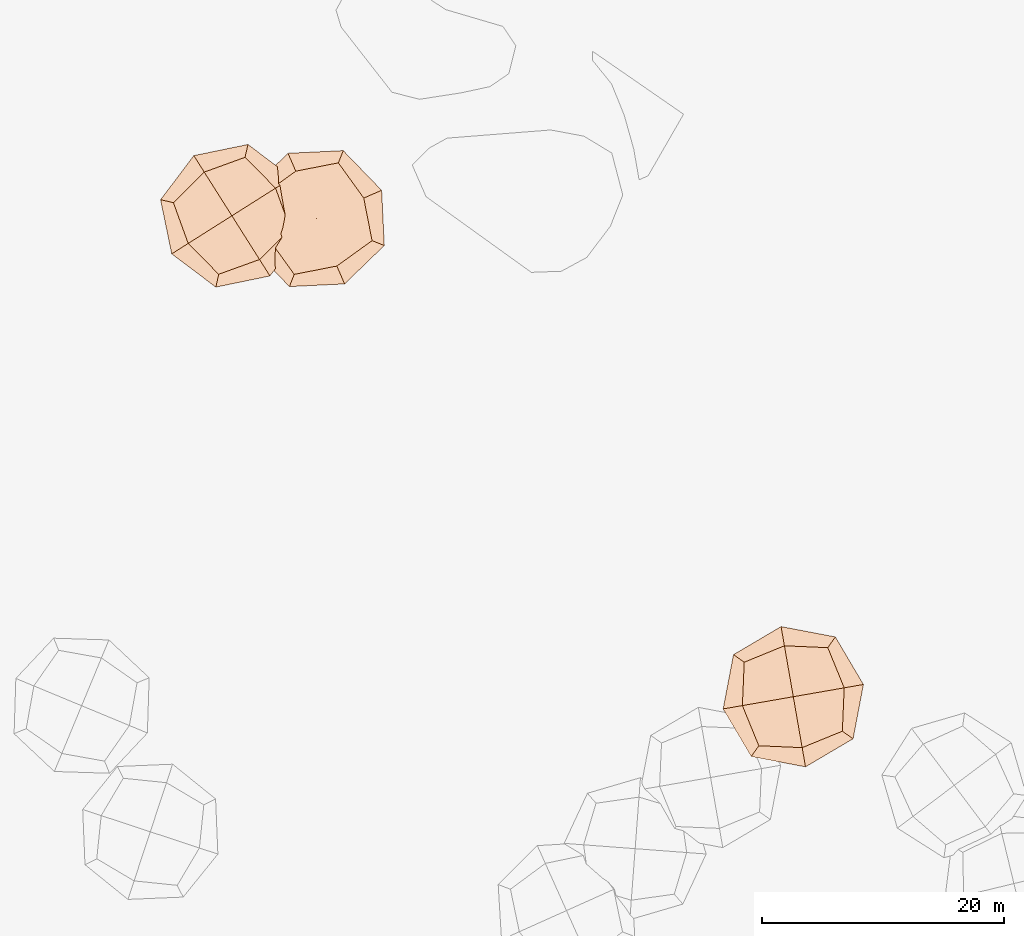
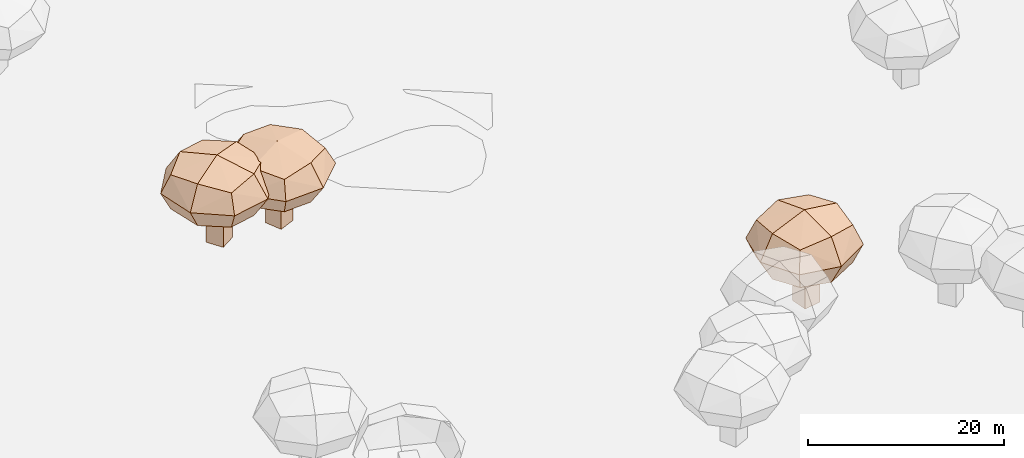
# Not in any storey, part 12 of 92: 3 geographic elements.
"""IFC4 model written with IfcOpenShell, lengths in metres."""

from ifc_helpers import new_model, si_unit, origin_with_axes, place, context, subcontext, project, spatial, triangles, material, element, save


model = new_model("IFC4")

# Units and contexts
model_context = context("Model", 3, precision=1e-05, world=origin_with_axes())
body_context = subcontext(model_context, "Body", "Model", "MODEL_VIEW")
ifc_project = project(units=[si_unit("VOLUMEUNIT", "CUBIC_METRE"), si_unit("LENGTHUNIT", "METRE"), si_unit("AREAUNIT", "SQUARE_METRE")], contexts=[model_context])

# Site
site_placement = place(None, origin_with_axes())
site = spatial("IfcSite", under=ifc_project, at=site_placement)

# Geographic elements
ifc_material = material(Name="tree")
geographic_element_1_placement = place(site_placement, origin_with_axes())
element("IfcGeographicElement", 1, at=geographic_element_1_placement, inside=site, material=ifc_material, Name="cw_instances_tree_168", context=body_context, shape_type="Tessellation", body=[
    triangles([(407.0424773080425, -716.6059607434237, 6.081787157617667), (407.0424773080425, -716.6059607434237, 6.081787157617667), (407.0424773080425, -716.6059607434237, 6.081787157617667), (407.0424773080425, -716.6059607434237, 0.0), (407.0424773080425, -716.6059607434237, 0.0), (407.0424773080425, -716.6059607434237, 0.0), (405.352289608444, -717.6751967043442, 6.081787157617667), (405.352289608444, -717.6751967043442, 6.081787157617667), (405.352289608444, -717.6751967043442, 6.081787157617667), (405.352289608444, -717.6751967043442, 0.0), (405.352289608444, -717.6751967043442, 0.0), (405.352289608444, -717.6751967043442, 0.0), (405.973241347122, -714.9157730438252, 6.081787157617667), (405.973241347122, -714.9157730438252, 6.081787157617667), (405.973241347122, -714.9157730438252, 6.081787157617667), (405.973241347122, -714.9157730438252, 0.0), (405.973241347122, -714.9157730438252, 0.0), (405.973241347122, -714.9157730438252, 0.0), (404.28305364752345, -715.9850090047457, 6.081787157617667), (404.28305364752345, -715.9850090047457, 6.081787157617667), (404.28305364752345, -715.9850090047457, 6.081787157617667), (404.28305364752345, -715.9850090047457, 0.0), (404.28305364752345, -715.9850090047457, 0.0), (404.28305364752345, -715.9850090047457, 0.0), (410.3587714953883, -717.1719350894241, 9.059218652031145), (410.3587714953883, -717.1719350894241, 9.059218652031145), (410.3587714953883, -717.1719350894241, 9.059218652031145), (410.3587714953883, -717.1719350894241, 9.059218652031145), (410.3587714953883, -717.1719350894241, 9.059218652031145), (410.3587714953883, -717.1719350894241, 9.059218652031145), (410.35877202934165, -717.17193503563, 4.801967811988829), (410.35877202934165, -717.17193503563, 4.801967811988829), (410.35877202934165, -717.17193503563, 4.801967811988829), (410.35877202934165, -717.17193503563, 4.801967811988829), (410.35877202934165, -717.17193503563, 4.801967811988829), (410.35877202934165, -717.17193503563, 4.801967811988829), (404.44311608640834, -720.9142602626565, 9.059218652031145), (404.44311608640834, -720.9142602626565, 9.059218652031145), (404.44311608640834, -720.9142602626565, 9.059218652031145), (404.44311608640834, -720.9142602626565, 9.059218652031145), (404.44311608640834, -720.9142602626565, 9.059218652031145), (404.44311608640834, -720.9142602626565, 9.059218652031145), (404.44311608640834, -720.9142602626565, 4.801967811988829), (404.44311608640834, -720.9142602626565, 4.801967811988829), (404.44311608640834, -720.9142602626565, 4.801967811988829), (404.44311608640834, -720.9142602626565, 4.801967811988829), (404.44311608640834, -720.9142602626565, 4.801967811988829), (404.44311608640834, -720.9142602626565, 4.801967811988829), (406.61644641739025, -711.256278484229, 9.059218652031145), (406.61644641739025, -711.256278484229, 9.059218652031145), (406.61644641739025, -711.256278484229, 9.059218652031145), (406.61644641739025, -711.256278484229, 9.059218652031145), (406.61644641739025, -711.256278484229, 9.059218652031145), (406.61644641739025, -711.256278484229, 9.059218652031145), (406.61644667400685, -711.2562788898741, 4.801967811988829), (406.61644667400685, -711.2562788898741, 4.801967811988829), (406.61644667400685, -711.2562788898741, 4.801967811988829), (406.61644667400685, -711.2562788898741, 4.801967811988829), (406.61644667400685, -711.2562788898741, 4.801967811988829), (406.61644667400685, -711.2562788898741, 4.801967811988829), (400.7007902716344, -714.9986038395639, 9.059218652031145), (400.7007902716344, -714.9986038395639, 9.059218652031145), (400.7007902716344, -714.9986038395639, 9.059218652031145), (400.7007902716344, -714.9986038395639, 9.059218652031145), (400.7007902716344, -714.9986038395639, 9.059218652031145), (400.7007902716344, -714.9986038395639, 9.059218652031145), (400.7007904744569, -714.9986037112556, 4.801967811988829), (400.7007904744569, -714.9986037112556, 4.801967811988829), (400.7007904744569, -714.9986037112556, 4.801967811988829), (400.7007904744569, -714.9986037112556, 4.801967811988829), (400.7007904744569, -714.9986037112556, 4.801967811988829), (400.7007904744569, -714.9986037112556, 4.801967811988829), (403.2485797490418, -712.4792753820734, 4.335510460840851), (403.2485797490418, -712.4792753820734, 4.335510460840851), (403.2485797490418, -712.4792753820734, 4.335510460840851), (403.2485797490418, -712.4792753820734, 4.335510460840851), (409.1357748355483, -713.8040683296758, 4.335510460840851), (409.1357748355483, -713.8040683296758, 4.335510460840851), (409.1357748355483, -713.8040683296758, 4.335510460840851), (409.1357748355483, -713.8040683296758, 4.335510460840851), (411.416975954336, -717.4100619664463, 6.930593596917239), (411.416975954336, -717.4100619664463, 6.930593596917239), (411.416975954336, -717.4100619664463, 6.930593596917239), (411.416975954336, -717.4100619664463, 6.930593596917239), (399.6425860953696, -714.7604765115535, 6.930593596917239), (399.6425860953696, -714.7604765115535, 6.930593596917239), (399.6425860953696, -714.7604765115535, 6.930593596917239), (399.6425860953696, -714.7604765115535, 6.930593596917239), (404.204988475715, -721.9724648899095, 6.930593596917239), (404.204988475715, -721.9724648899095, 6.930593596917239), (404.204988475715, -721.9724648899095, 6.930593596917239), (404.204988475715, -721.9724648899095, 6.930593596917239), (406.85457368468354, -710.1980746421999, 6.930593596917239), (406.85457368468354, -710.1980746421999, 6.930593596917239), (406.85457368468354, -710.1980746421999, 6.930593596917239), (406.85457368468354, -710.1980746421999, 6.930593596917239), (401.9237871056569, -718.366470855945, 9.52567563827187), (401.9237871056569, -718.366470855945, 9.52567563827187), (401.9237871056569, -718.366470855945, 9.52567563827187), (401.9237871056569, -718.366470855945, 9.52567563827187), (407.81098261109076, -719.6912634556971, 9.525677067491939), (407.81098261109076, -719.6912634556971, 9.525677067491939), (407.81098261109076, -719.6912634556971, 9.525677067491939), (407.81098261109076, -719.6912634556971, 9.525677067491939), (401.9237874761201, -718.3664705624199, 4.335510460840851), (401.9237874761201, -718.3664705624199, 4.335510460840851), (401.9237874761201, -718.3664705624199, 4.335510460840851), (401.9237874761201, -718.3664705624199, 4.335510460840851), (403.2485797828456, -712.4792753606887, 9.52567563827187), (403.2485797828456, -712.4792753606887, 9.52567563827187), (403.2485797828456, -712.4792753606887, 9.52567563827187), (403.2485797828456, -712.4792753606887, 9.52567563827187), (409.13577485158686, -713.8040683550287, 9.525677067491939), (409.13577485158686, -713.8040683550287, 9.525677067491939), (409.13577485158686, -713.8040683550287, 9.525677067491939), (409.13577485158686, -713.8040683550287, 9.525677067491939), (407.8109823091147, -719.6912630905802, 4.335510460840851), (407.8109823091147, -719.6912630905802, 4.335510460840851), (407.8109823091147, -719.6912630905802, 4.335510460840851), (407.8109823091147, -719.6912630905802, 4.335510460840851), (405.52978125741976, -716.0852693167019, 10.50458249030473), (405.52978125741976, -716.0852693167019, 10.50458249030473), (405.52978125741976, -716.0852693167019, 10.50458249030473), (405.52978125741976, -716.0852693167019, 10.50458249030473), (405.52978125741976, -716.0852693167019, 10.50458249030473), (405.52978125741976, -716.0852693167019, 10.50458249030473), (405.52978125741976, -716.0852693167019, 10.50458249030473), (405.52978125741976, -716.0852693167019, 10.50458249030473), (400.56355139225695, -719.226974657056, 6.930593596917239), (400.56355139225695, -719.226974657056, 6.930593596917239), (400.56355139225695, -719.226974657056, 6.930593596917239), (400.56355139225695, -719.226974657056, 6.930593596917239), (400.56355139225695, -719.226974657056, 6.930593596917239), (400.56355139225695, -719.226974657056, 6.930593596917239), (400.56355139225695, -719.226974657056, 6.930593596917239), (400.56355139225695, -719.226974657056, 6.930593596917239), (402.38807597328366, -711.1190396526349, 6.930593596917239), (402.38807597328366, -711.1190396526349, 6.930593596917239), (402.38807597328366, -711.1190396526349, 6.930593596917239), (402.38807597328366, -711.1190396526349, 6.930593596917239), (402.38807597328366, -711.1190396526349, 6.930593596917239), (402.38807597328366, -711.1190396526349, 6.930593596917239), (402.38807597328366, -711.1190396526349, 6.930593596917239), (402.38807597328366, -711.1190396526349, 6.930593596917239), (405.5297813322663, -716.0852694350151, 3.3566054029353123), (405.5297813322663, -716.0852694350151, 3.3566054029353123), (405.5297813322663, -716.0852694350151, 3.3566054029353123), (405.5297813322663, -716.0852694350151, 3.3566054029353123), (405.5297813322663, -716.0852694350151, 3.3566054029353123), (405.5297813322663, -716.0852694350151, 3.3566054029353123), (405.5297813322663, -716.0852694350151, 3.3566054029353123), (405.5297813322663, -716.0852694350151, 3.3566054029353123), (408.6714862200879, -721.0514987344798, 6.930593596917239), (408.6714862200879, -721.0514987344798, 6.930593596917239), (408.6714862200879, -721.0514987344798, 6.930593596917239), (408.6714862200879, -721.0514987344798, 6.930593596917239), (408.6714862200879, -721.0514987344798, 6.930593596917239), (408.6714862200879, -721.0514987344798, 6.930593596917239), (408.6714862200879, -721.0514987344798, 6.930593596917239), (408.6714862200879, -721.0514987344798, 6.930593596917239), (410.4960109278624, -712.9435642296936, 6.930593596917239), (410.4960109278624, -712.9435642296936, 6.930593596917239), (410.4960109278624, -712.9435642296936, 6.930593596917239), (410.4960109278624, -712.9435642296936, 6.930593596917239), (410.4960109278624, -712.9435642296936, 6.930593596917239), (410.4960109278624, -712.9435642296936, 6.930593596917239), (410.4960109278624, -712.9435642296936, 6.930593596917239), (410.4960109278624, -712.9435642296936, 6.930593596917239)], [[15, 8, 2], [7, 24, 11], [19, 16, 22], [4, 23, 17], [3, 12, 6], [14, 5, 18], [26, 127, 101], [54, 123, 114], [124, 66, 98], [128, 38, 102], [45, 133, 108], [40, 135, 89], [130, 63, 88], [131, 70, 105], [68, 141, 73], [61, 140, 86], [137, 49, 93], [142, 56, 74], [59, 145, 75], [31, 149, 79], [150, 43, 107], [146, 71, 76], [35, 154, 120], [30, 157, 83], [158, 42, 91], [153, 47, 119], [58, 164, 77], [51, 162, 96], [167, 28, 81], [165, 33, 80], [15, 21, 8], [7, 20, 24], [19, 13, 16], [4, 10, 23], [3, 9, 12], [14, 1, 5], [25, 115, 126], [53, 111, 121], [122, 112, 65], [125, 99, 37], [46, 90, 136], [39, 100, 134], [132, 97, 64], [129, 87, 69], [67, 85, 138], [62, 110, 144], [143, 109, 50], [139, 94, 55], [60, 78, 147], [32, 117, 151], [152, 118, 44], [148, 106, 72], [36, 84, 160], [29, 104, 156], [155, 103, 41], [159, 92, 48], [57, 95, 161], [52, 113, 163], [166, 116, 27], [168, 82, 34]], closed=True),
])
geographic_element_2_placement = place(site_placement, origin_with_axes())
element("IfcGeographicElement", 2, at=geographic_element_2_placement, inside=site, material=ifc_material, Name="cw_instances_tree_169", context=body_context, shape_type="Tessellation", body=[
    triangles([(413.9124796540221, -717.0660086138839, 5.74902106776371), (413.9124796540221, -717.0660086138839, 5.74902106776371), (413.9124796540221, -717.0660086138839, 5.74902106776371), (413.9124796540221, -717.0660086138839, 0.0), (413.9124796540221, -717.0660086138839, 0.0), (413.9124796540221, -717.0660086138839, 0.0), (412.07722297918787, -717.8608878106656, 5.74902106776371), (412.07722297918787, -717.8608878106656, 5.74902106776371), (412.07722297918787, -717.8608878106656, 5.74902106776371), (412.07722297918787, -717.8608878106656, 0.0), (412.07722297918787, -717.8608878106656, 0.0), (412.07722297918787, -717.8608878106656, 0.0), (413.1176004572403, -715.2307519390497, 5.74902106776371), (413.1176004572403, -715.2307519390497, 5.74902106776371), (413.1176004572403, -715.2307519390497, 5.74902106776371), (413.1176004572403, -715.2307519390497, 0.0), (413.1176004572403, -715.2307519390497, 0.0), (413.1176004572403, -715.2307519390497, 0.0), (411.2823437824061, -716.0256311358314, 5.74902106776371), (411.2823437824061, -716.0256311358314, 5.74902106776371), (411.2823437824061, -716.0256311358314, 5.74902106776371), (411.2823437824061, -716.0256311358314, 0.0), (411.2823437824061, -716.0256311358314, 0.0), (411.2823437824061, -716.0256311358314, 0.0), (417.10128694424435, -718.1382222881014, 8.563541856733806), (417.10128694424435, -718.1382222881014, 8.563541856733806), (417.10128694424435, -718.1382222881014, 8.563541856733806), (417.10128694424435, -718.1382222881014, 8.563541856733806), (417.10128694424435, -718.1382222881014, 8.563541856733806), (417.10128694424435, -718.1382222881014, 8.563541856733806), (417.10128748009146, -718.1382223175611, 4.539227270271809), (417.10128748009146, -718.1382223175611, 4.539227270271809), (417.10128748009146, -718.1382223175611, 4.539227270271809), (417.10128748009146, -718.1382223175611, 4.539227270271809), (417.10128748009146, -718.1382223175611, 4.539227270271809), (417.10128748009146, -718.1382223175611, 4.539227270271809), (410.6778902101494, -720.9202990333443, 8.563541856733806), (410.6778902101494, -720.9202990333443, 8.563541856733806), (410.6778902101494, -720.9202990333443, 8.563541856733806), (410.6778902101494, -720.9202990333443, 8.563541856733806), (410.6778902101494, -720.9202990333443, 8.563541856733806), (410.6778902101494, -720.9202990333443, 8.563541856733806), (410.6778902101494, -720.9202990333443, 4.539227270271809), (410.6778902101494, -720.9202990333443, 4.539227270271809), (410.6778902101494, -720.9202990333443, 4.539227270271809), (410.6778902101494, -720.9202990333443, 4.539227270271809), (410.6778902101494, -720.9202990333443, 4.539227270271809), (410.6778902101494, -720.9202990333443, 4.539227270271809), (414.31921047815183, -711.7148243869268, 8.563541856733806), (414.31921047815183, -711.7148243869268, 8.563541856733806), (414.31921047815183, -711.7148243869268, 8.563541856733806), (414.31921047815183, -711.7148243869268, 8.563541856733806), (414.31921047815183, -711.7148243869268, 8.563541856733806), (414.31921047815183, -711.7148243869268, 8.563541856733806), (414.31921066892284, -711.7148248273884, 4.539227270271809), (414.31921066892284, -711.7148248273884, 4.539227270271809), (414.31921066892284, -711.7148248273884, 4.539227270271809), (414.31921066892284, -711.7148248273884, 4.539227270271809), (414.31921066892284, -711.7148248273884, 4.539227270271809), (414.31921066892284, -711.7148248273884, 4.539227270271809), (407.895812987979, -714.4969011980953, 8.563541856733806), (407.895812987979, -714.4969011980953, 8.563541856733806), (407.895812987979, -714.4969011980953, 8.563541856733806), (407.895812987979, -714.4969011980953, 8.563541856733806), (407.895812987979, -714.4969011980953, 8.563541856733806), (407.895812987979, -714.4969011980953, 8.563541856733806), (407.8958132082098, -714.4969011027099, 4.539227270271809), (407.8958132082098, -714.4969011027099, 4.539227270271809), (407.8958132082098, -714.4969011027099, 4.539227270271809), (407.8958132082098, -714.4969011027099, 4.539227270271809), (407.8958132082098, -714.4969011027099, 4.539227270271809), (407.8958132082098, -714.4969011027099, 4.539227270271809), (410.8026855151203, -712.4020648777924, 4.098292217882794), (410.8026855151203, -712.4020648777924, 4.098292217882794), (410.8026855151203, -712.4020648777924, 4.098292217882794), (410.8026855151203, -712.4020648777924, 4.098292217882794), (416.41404670265774, -714.6216972715914, 4.098292217882794), (416.41404670265774, -714.6216972715914, 4.098292217882794), (416.41404670265774, -714.6216972715914, 4.098292217882794), (416.41404670265774, -714.6216972715914, 4.098292217882794), (418.1099112071012, -718.5371936941865, 6.551384908444093), (418.1099112071012, -718.5371936941865, 6.551384908444093), (418.1099112071012, -718.5371936941865, 6.551384908444093), (418.1099112071012, -718.5371936941865, 6.551384908444093), (406.8871890741726, -714.0979293901847, 6.551384908444093), (406.8871890741726, -714.0979293901847, 6.551384908444093), (406.8871890741726, -714.0979293901847, 6.551384908444093), (406.8871890741726, -714.0979293901847, 6.551384908444093), (410.2789180531883, -721.9289233489762, 6.551384908444093), (410.2789180531883, -721.9289233489762, 6.551384908444093), (410.2789180531883, -721.9289233489762, 6.551384908444093), (410.2789180531883, -721.9289233489762, 6.551384908444093), (414.7181821743679, -710.7062007939386, 6.551384908444093), (414.7181821743679, -710.7062007939386, 6.551384908444093), (414.7181821743679, -710.7062007939386, 6.551384908444093), (414.7181821743679, -710.7062007939386, 6.551384908444093), (408.5830533619482, -718.0134264950958, 9.004476564181536), (408.5830533619482, -718.0134264950958, 9.004476564181536), (408.5830533619482, -718.0134264950958, 9.004476564181536), (408.5830533619482, -718.0134264950958, 9.004476564181536), (414.19441501718416, -720.2330586100434, 9.004477915201567), (414.19441501718416, -720.2330586100434, 9.004477915201567), (414.19441501718416, -720.2330586100434, 9.004477915201567), (414.19441501718416, -720.2330586100434, 9.004477915201567), (408.58305377336154, -718.0134262624177, 4.098292217882794), (408.58305377336154, -718.0134262624177, 4.098292217882794), (408.58305377336154, -718.0134262624177, 4.098292217882794), (408.58305377336154, -718.0134262624177, 4.098292217882794), (410.80268555182545, -712.4020648618948, 9.004476564181536), (410.80268555182545, -712.4020648618948, 9.004476564181536), (410.80268555182545, -712.4020648618948, 9.004476564181536), (410.80268555182545, -712.4020648618948, 9.004476564181536), (416.41404671458093, -714.6216972991202, 9.004477915201567), (416.41404671458093, -714.6216972991202, 9.004477915201567), (416.41404671458093, -714.6216972991202, 9.004477915201567), (416.41404671458093, -714.6216972991202, 9.004477915201567), (414.19441477532985, -720.2330582026044, 4.098292217882794), (414.19441477532985, -720.2330582026044, 4.098292217882794), (414.19441477532985, -720.2330582026044, 4.098292217882794), (414.19441477532985, -720.2330582026044, 4.098292217882794), (412.49855035838283, -716.3175616549319, 9.929822349863327), (412.49855035838283, -716.3175616549319, 9.929822349863327), (412.49855035838283, -716.3175616549319, 9.929822349863327), (412.49855035838283, -716.3175616549319, 9.929822349863327), (412.49855035838283, -716.3175616549319, 9.929822349863327), (412.49855035838283, -716.3175616549319, 9.929822349863327), (412.49855035838283, -716.3175616549319, 9.929822349863327), (412.49855035838283, -716.3175616549319, 9.929822349863327), (407.1060684844946, -718.6531324115203, 6.551384908444093), (407.1060684844946, -718.6531324115203, 6.551384908444093), (407.1060684844946, -718.6531324115203, 6.551384908444093), (407.1060684844946, -718.6531324115203, 6.551384908444093), (407.1060684844946, -718.6531324115203, 6.551384908444093), (407.1060684844946, -718.6531324115203, 6.551384908444093), (407.1060684844946, -718.6531324115203, 6.551384908444093), (407.1060684844946, -718.6531324115203, 6.551384908444093), (410.16297962622457, -710.9250799884156, 6.551384908444093), (410.16297962622457, -710.9250799884156, 6.551384908444093), (410.16297962622457, -710.9250799884156, 6.551384908444093), (410.16297962622457, -710.9250799884156, 6.551384908444093), (410.16297962622457, -710.9250799884156, 6.551384908444093), (410.16297962622457, -710.9250799884156, 6.551384908444093), (410.16297962622457, -710.9250799884156, 6.551384908444093), (410.16297962622457, -710.9250799884156, 6.551384908444093), (412.4985504140244, -716.3175617833998, 3.172948128162319), (412.4985504140244, -716.3175617833998, 3.172948128162319), (412.4985504140244, -716.3175617833998, 3.172948128162319), (412.4985504140244, -716.3175617833998, 3.172948128162319), (412.4985504140244, -716.3175617833998, 3.172948128162319), (412.4985504140244, -716.3175617833998, 3.172948128162319), (412.4985504140244, -716.3175617833998, 3.172948128162319), (412.4985504140244, -716.3175617833998, 3.172948128162319), (414.8341208110461, -721.7100430283908, 6.551384908444093), (414.8341208110461, -721.7100430283908, 6.551384908444093), (414.8341208110461, -721.7100430283908, 6.551384908444093), (414.8341208110461, -721.7100430283908, 6.551384908444093), (414.8341208110461, -721.7100430283908, 6.551384908444093), (414.8341208110461, -721.7100430283908, 6.551384908444093), (414.8341208110461, -721.7100430283908, 6.551384908444093), (414.8341208110461, -721.7100430283908, 6.551384908444093), (417.89103200070093, -713.9819911185144, 6.551384908444093), (417.89103200070093, -713.9819911185144, 6.551384908444093), (417.89103200070093, -713.9819911185144, 6.551384908444093), (417.89103200070093, -713.9819911185144, 6.551384908444093), (417.89103200070093, -713.9819911185144, 6.551384908444093), (417.89103200070093, -713.9819911185144, 6.551384908444093), (417.89103200070093, -713.9819911185144, 6.551384908444093), (417.89103200070093, -713.9819911185144, 6.551384908444093)], [[15, 8, 2], [7, 24, 11], [19, 16, 22], [4, 23, 17], [3, 12, 6], [14, 5, 18], [26, 127, 101], [54, 123, 114], [124, 66, 98], [128, 38, 102], [45, 133, 108], [40, 135, 89], [130, 63, 88], [131, 70, 105], [68, 141, 73], [61, 140, 86], [137, 49, 93], [142, 56, 74], [59, 145, 75], [31, 149, 79], [150, 43, 107], [146, 71, 76], [35, 154, 120], [30, 157, 83], [158, 42, 91], [153, 47, 119], [58, 164, 77], [51, 162, 96], [167, 28, 81], [165, 33, 80], [15, 21, 8], [7, 20, 24], [19, 13, 16], [4, 10, 23], [3, 9, 12], [14, 1, 5], [25, 115, 126], [53, 111, 121], [122, 112, 65], [125, 99, 37], [46, 90, 136], [39, 100, 134], [132, 97, 64], [129, 87, 69], [67, 85, 138], [62, 110, 144], [143, 109, 50], [139, 94, 55], [60, 78, 147], [32, 117, 151], [152, 118, 44], [148, 106, 72], [36, 84, 160], [29, 104, 156], [155, 103, 41], [159, 92, 48], [57, 95, 161], [52, 113, 163], [166, 116, 27], [168, 82, 34]], closed=True),
])
geographic_element_3_placement = place(site_placement, origin_with_axes())
element("IfcGeographicElement", 3, at=geographic_element_3_placement, inside=site, material=ifc_material, Name="cw_instances_tree_194", context=body_context, shape_type="Tessellation", body=[
    triangles([(452.9306892715029, -754.5845452372156, 6.673620415170163), (452.9306892715029, -754.5845452372156, 6.673620415170163), (452.9306892715029, -754.5845452372156, 6.673620415170163), (452.9306892715029, -754.5845452372156, 0.0), (452.9306892715029, -754.5845452372156, 0.0), (452.9306892715029, -754.5845452372156, 0.0), (453.2739406556983, -756.554869699645, 6.673620415170163), (453.2739406556983, -756.554869699645, 6.673620415170163), (453.2739406556983, -756.554869699645, 6.673620415170163), (453.2739406556983, -756.554869699645, 0.0), (453.2739406556983, -756.554869699645, 0.0), (453.2739406556983, -756.554869699645, 0.0), (450.96036480907344, -754.927796621411, 6.673620415170163), (450.96036480907344, -754.927796621411, 6.673620415170163), (450.96036480907344, -754.927796621411, 6.673620415170163), (450.96036480907344, -754.927796621411, 0.0), (450.96036480907344, -754.927796621411, 0.0), (450.96036480907344, -754.927796621411, 0.0), (451.30361619326885, -756.8981210838405, 6.673620415170163), (451.30361619326885, -756.8981210838405, 6.673620415170163), (451.30361619326885, -756.8981210838405, 6.673620415170163), (451.30361619326885, -756.8981210838405, 0.0), (451.30361619326885, -756.8981210838405, 0.0), (451.30361619326885, -756.8981210838405, 0.0), (454.7194734666857, -751.735267223329, 9.940792891109274), (454.7194734666857, -751.735267223329, 9.940792891109274), (454.7194734666857, -751.735267223329, 9.940792891109274), (454.7194734666857, -751.735267223329, 9.940792891109274), (454.7194734666857, -751.735267223329, 9.940792891109274), (454.7194734666857, -751.735267223329, 9.940792891109274), (454.71947362074434, -751.7352667092608, 5.269258787351542), (454.71947362074434, -751.7352667092608, 5.269258787351542), (454.71947362074434, -751.7352667092608, 5.269258787351542), (454.71947362074434, -751.7352667092608, 5.269258787351542), (454.71947362074434, -751.7352667092608, 5.269258787351542), (454.71947362074434, -751.7352667092608, 5.269258787351542), (455.92085326119366, -758.6314011554209, 9.940792891109274), (455.92085326119366, -758.6314011554209, 9.940792891109274), (455.92085326119366, -758.6314011554209, 9.940792891109274), (455.92085326119366, -758.6314011554209, 9.940792891109274), (455.92085326119366, -758.6314011554209, 9.940792891109274), (455.92085326119366, -758.6314011554209, 9.940792891109274), (455.92085326119366, -758.6314011554209, 5.269258787351542), (455.92085326119366, -758.6314011554209, 5.269258787351542), (455.92085326119366, -758.6314011554209, 5.269258787351542), (455.92085326119366, -758.6314011554209, 5.269258787351542), (455.92085326119366, -758.6314011554209, 5.269258787351542), (455.92085326119366, -758.6314011554209, 5.269258787351542), (447.82333846526745, -752.9366464732807, 9.940792891109274), (447.82333846526745, -752.9366464732807, 9.940792891109274), (447.82333846526745, -752.9366464732807, 9.940792891109274), (447.82333846526745, -752.9366464732807, 9.940792891109274), (447.82333846526745, -752.9366464732807, 9.940792891109274), (447.82333846526745, -752.9366464732807, 9.940792891109274), (447.82333893814535, -752.9366463909004, 5.269258787351542), (447.82333893814535, -752.9366463909004, 5.269258787351542), (447.82333893814535, -752.9366463909004, 5.269258787351542), (447.82333893814535, -752.9366463909004, 5.269258787351542), (447.82333893814535, -752.9366463909004, 5.269258787351542), (447.82333893814535, -752.9366463909004, 5.269258787351542), (449.024718146907, -759.8327811558797, 9.940792891109274), (449.024718146907, -759.8327811558797, 9.940792891109274), (449.024718146907, -759.8327811558797, 9.940792891109274), (449.024718146907, -759.8327811558797, 9.940792891109274), (449.024718146907, -759.8327811558797, 9.940792891109274), (449.024718146907, -759.8327811558797, 9.940792891109274), (449.02471810571683, -759.8327809194408, 5.269258787351542), (449.02471810571683, -759.8327809194408, 5.269258787351542), (449.02471810571683, -759.8327809194408, 5.269258787351542), (449.02471810571683, -759.8327809194408, 5.269258787351542), (449.02471810571683, -759.8327809194408, 5.269258787351542), (449.02471810571683, -759.8327809194408, 5.269258787351542), (447.66843358518867, -756.5163464308242, 4.757409355473899), (447.66843358518867, -756.5163464308242, 4.757409355473899), (447.66843358518867, -756.5163464308242, 4.757409355473899), (447.66843358518867, -756.5163464308242, 4.757409355473899), (451.1397735154939, -751.5803620883783, 4.757409355473899), (451.1397735154939, -751.5803620883783, 4.757409355473899), (451.1397735154939, -751.5803620883783, 4.757409355473899), (451.1397735154939, -751.5803620883783, 4.757409355473899), (455.34343531919836, -750.8480396915727, 7.605026239647657), (455.34343531919836, -750.8480396915727, 7.605026239647657), (455.34343531919836, -750.8480396915727, 7.605026239647657), (455.34343531919836, -750.8480396915727, 7.605026239647657), (448.4007559854267, -760.7200082542319, 7.605026239647657), (448.4007559854267, -760.7200082542319, 7.605026239647657), (448.4007559854267, -760.7200082542319, 7.605026239647657), (448.4007559854267, -760.7200082542319, 7.605026239647657), (456.8080806685135, -759.2553637503052, 7.605026239647657), (456.8080806685135, -759.2553637503052, 7.605026239647657), (456.8080806685135, -759.2553637503052, 7.605026239647657), (456.8080806685135, -759.2553637503052, 7.605026239647657), (446.93611165267976, -752.3126844954813, 7.605026239647657), (446.93611165267976, -752.3126844954813, 7.605026239647657), (446.93611165267976, -752.3126844954813, 7.605026239647657), (446.93611165267976, -752.3126844954813, 7.605026239647657), (452.6044184017828, -759.9876862277747, 10.452641922569665), (452.6044184017828, -759.9876862277747, 10.452641922569665), (452.6044184017828, -759.9876862277747, 10.452641922569665), (452.6044184017828, -759.9876862277747, 10.452641922569665), (456.07575817044886, -755.051701365355, 10.452643490870559), (456.07575817044886, -755.051701365355, 10.452643490870559), (456.07575817044886, -755.051701365355, 10.452643490870559), (456.07575817044886, -755.051701365355, 10.452643490870559), (452.60441827186065, -759.9876857733298, 4.757409355473899), (452.60441827186065, -759.9876857733298, 4.757409355473899), (452.60441827186065, -759.9876857733298, 4.757409355473899), (452.60441827186065, -759.9876857733298, 4.757409355473899), (447.66843357832363, -756.5163463914178, 10.452641922569665), (447.66843357832363, -756.5163463914178, 10.452641922569665), (447.66843357832363, -756.5163463914178, 10.452641922569665), (447.66843357832363, -756.5163463914178, 10.452641922569665), (451.1397735450488, -751.5803620832295, 10.452643490870559), (451.1397735450488, -751.5803620832295, 10.452643490870559), (451.1397735450488, -751.5803620832295, 10.452643490870559), (451.1397735450488, -751.5803620832295, 10.452643490870559), (456.07575771772014, -755.0517015051288, 4.757409355473899), (456.07575771772014, -755.0517015051288, 4.757409355473899), (456.07575771772014, -755.0517015051288, 4.757409355473899), (456.07575771772014, -755.0517015051288, 4.757409355473899), (451.87209581289136, -755.7840237875932, 11.526808542178147), (451.87209581289136, -755.7840237875932, 11.526808542178147), (451.87209581289136, -755.7840237875932, 11.526808542178147), (451.87209581289136, -755.7840237875932, 11.526808542178147), (451.87209581289136, -755.7840237875932, 11.526808542178147), (451.87209581289136, -755.7840237875932, 11.526808542178147), (451.87209581289136, -755.7840237875932, 11.526808542178147), (451.87209581289136, -755.7840237875932, 11.526808542178147), (452.8806615619759, -761.5733714752881, 7.605026239647657), (452.8806615619759, -761.5733714752881, 7.605026239647657), (452.8806615619759, -761.5733714752881, 7.605026239647657), (452.8806615619759, -761.5733714752881, 7.605026239647657), (452.8806615619759, -761.5733714752881, 7.605026239647657), (452.8806615619759, -761.5733714752881, 7.605026239647657), (452.8806615619759, -761.5733714752881, 7.605026239647657), (452.8806615619759, -761.5733714752881, 7.605026239647657), (446.0827483325265, -756.7925895614624, 7.605026239647657), (446.0827483325265, -756.7925895614624, 7.605026239647657), (446.0827483325265, -756.7925895614624, 7.605026239647657), (446.0827483325265, -756.7925895614624, 7.605026239647657), (446.0827483325265, -756.7925895614624, 7.605026239647657), (446.0827483325265, -756.7925895614624, 7.605026239647657), (446.0827483325265, -756.7925895614624, 7.605026239647657), (446.0827483325265, -756.7925895614624, 7.605026239647657), (451.87209595081407, -755.7840237635656, 3.6832447045835597), (451.87209595081407, -755.7840237635656, 3.6832447045835597), (451.87209595081407, -755.7840237635656, 3.6832447045835597), (451.87209595081407, -755.7840237635656, 3.6832447045835597), (451.87209595081407, -755.7840237635656, 3.6832447045835597), (451.87209595081407, -755.7840237635656, 3.6832447045835597), (451.87209595081407, -755.7840237635656, 3.6832447045835597), (451.87209595081407, -755.7840237635656, 3.6832447045835597), (457.66144294292224, -754.7754582168646, 7.605026239647657), (457.66144294292224, -754.7754582168646, 7.605026239647657), (457.66144294292224, -754.7754582168646, 7.605026239647657), (457.66144294292224, -754.7754582168646, 7.605026239647657), (457.66144294292224, -754.7754582168646, 7.605026239647657), (457.66144294292224, -754.7754582168646, 7.605026239647657), (457.66144294292224, -754.7754582168646, 7.605026239647657), (457.66144294292224, -754.7754582168646, 7.605026239647657), (450.8635302236624, -749.9946763765682, 7.605026239647657), (450.8635302236624, -749.9946763765682, 7.605026239647657), (450.8635302236624, -749.9946763765682, 7.605026239647657), (450.8635302236624, -749.9946763765682, 7.605026239647657), (450.8635302236624, -749.9946763765682, 7.605026239647657), (450.8635302236624, -749.9946763765682, 7.605026239647657), (450.8635302236624, -749.9946763765682, 7.605026239647657), (450.8635302236624, -749.9946763765682, 7.605026239647657)], [[15, 8, 2], [7, 24, 11], [19, 16, 22], [4, 23, 17], [3, 12, 6], [14, 5, 18], [26, 127, 101], [54, 123, 114], [124, 66, 98], [128, 38, 102], [45, 133, 108], [40, 135, 89], [130, 63, 88], [131, 70, 105], [68, 141, 73], [61, 140, 86], [137, 49, 93], [142, 56, 74], [59, 145, 75], [31, 149, 79], [150, 43, 107], [146, 71, 76], [35, 154, 120], [30, 157, 83], [158, 42, 91], [153, 47, 119], [58, 164, 77], [51, 162, 96], [167, 28, 81], [165, 33, 80], [15, 21, 8], [7, 20, 24], [19, 13, 16], [4, 10, 23], [3, 9, 12], [14, 1, 5], [25, 115, 126], [53, 111, 121], [122, 112, 65], [125, 99, 37], [46, 90, 136], [39, 100, 134], [132, 97, 64], [129, 87, 69], [67, 85, 138], [62, 110, 144], [143, 109, 50], [139, 94, 55], [60, 78, 147], [32, 117, 151], [152, 118, 44], [148, 106, 72], [36, 84, 160], [29, 104, 156], [155, 103, 41], [159, 92, 48], [57, 95, 161], [52, 113, 163], [166, 116, 27], [168, 82, 34]], closed=True),
])

save(model, "model.ifc")
